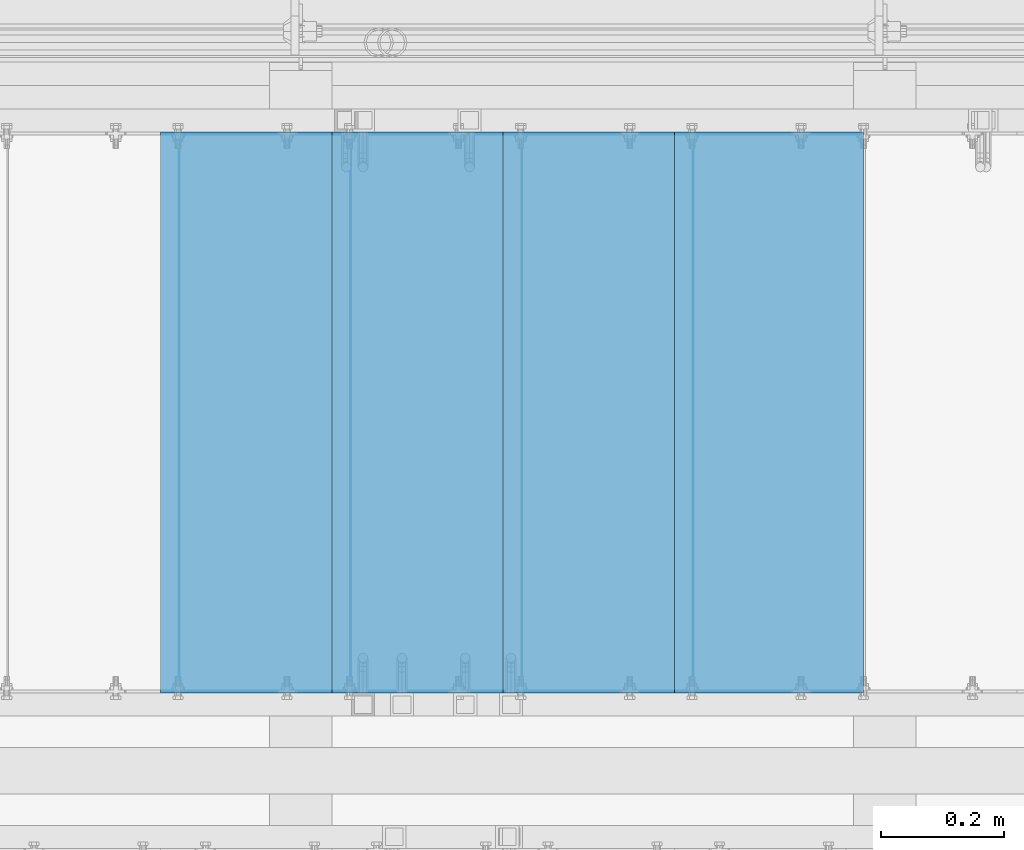
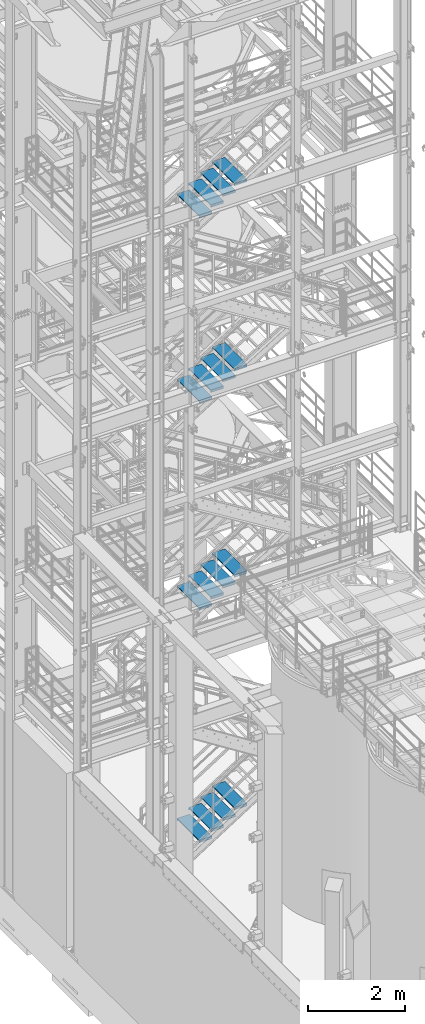
# One storey, part 1186 of 1876: 16 beams, 4 elements without a shape of their own.
"""IFC2X3 building model written with IfcOpenShell, lengths in millimetres."""

from ifc_helpers import new_model, si_unit, frame, origin_with_axes, place, context, subcontext, project, spatial, faceted_brep, material, type_object, element, aggregate, save


model = new_model("IFC2X3")

# Units and contexts
model_context = context("Model", 3, precision=1e-05, world=origin_with_axes())
body_context = subcontext(model_context, "Body", "Model", "MODEL_VIEW")
ifc_project = project(units=[si_unit("LENGTHUNIT", "METRE", prefix="MILLI"), si_unit("AREAUNIT", "SQUARE_METRE"), si_unit("VOLUMEUNIT", "CUBIC_METRE"), si_unit("MASSUNIT", "GRAM", prefix="KILO"), si_unit("TIMEUNIT", "SECOND"), si_unit("PLANEANGLEUNIT", "RADIAN"), si_unit("SOLIDANGLEUNIT", "STERADIAN"), si_unit("THERMODYNAMICTEMPERATUREUNIT", "DEGREE_CELSIUS"), si_unit("LUMINOUSINTENSITYUNIT", "LUMEN")], contexts=[model_context])

# Site, building, storey
site_placement = place(None, origin_with_axes())
site = spatial("IfcSite", under=ifc_project, at=site_placement, CompositionType="ELEMENT")
building_placement = place(site_placement, origin_with_axes())
building = spatial("IfcBuilding", under=site, at=building_placement, Name="Undefined", CompositionType="ELEMENT")
storey_placement = place(building_placement, origin_with_axes())
storey = spatial("IfcBuildingStorey", under=building, at=storey_placement, Name="Undefined", CompositionType="ELEMENT", Elevation=0.0)

# Assembly, beams
assembly_1_placement = place(storey_placement, origin_with_axes())
assembly_1 = element("IfcElementAssembly", 1, at=assembly_1_placement, inside=storey, Name="STRINGER", AssemblyPlace="NOTDEFINED", PredefinedType="RIGID_FRAME")
ifc_material = material(Name="STEEL/A36")
beam_type = type_object("IfcBeamType", PredefinedType="NOTDEFINED")
beam_1_placement = place(assembly_1_placement, frame((4573.58749594035, -5710.23700114434, 16944.6222227142), z_axis=(-1.0, 0.0, 0.0), x_axis=(0.0, 1.0, 0.0)))
beam_1 = element("IfcBeam", 2, at=beam_1_placement, type_object=beam_type, material=ifc_material, Name="TREAD", context=body_context, shape_type="Brep", body=[
    faceted_brep([(-7.45785655453801e-11, 53.9750000000167, -153.9875), (-7.45785655453801e-11, 53.9750000000167, 153.987506103515), (0.0, 9.52499999999964, 153.9875), (-7.45785655453801e-11, 9.52499999999964, -153.9875), (-4.76300000007541, 53.9750000000167, -153.9875), (-4.76300000007541, 53.9750000000167, 153.987506103515), (-4.76300000007541, -9.52499999998327, -153.9875), (-4.76300000007541, -9.52500000019427, 153.987536621094), (909.637000008669, -9.52500000248983, 153.987506103515), (909.637000008669, 53.9749999975102, 153.987506103515), (904.87400000867, 53.9749999975102, 153.987506103515), (904.87400000867, 9.52499999999964, 153.987506103515), (-7.45785655453801e-11, -9.52500000019427, 153.987536621094), (904.87400000867, -9.52500000248983, 153.987506103515), (904.87400000867, 9.52499999999964, -153.9875), (909.637000008669, -9.52500000248983, -153.9875), (909.637000008669, 53.9749999975102, -153.9875), (904.87400000867, 53.9749999975102, -153.9875)], [[[0, 1, 2, 3]], [[1, 0, 4, 5]], [[5, 4, 6, 7]], [[8, 9, 10, 11, 2, 1, 5, 7, 12, 13]], [[14, 3, 2, 11]], [[15, 8, 13, 12, 7, 6]], [[9, 16, 17, 10]], [[16, 9, 8, 15]], [[16, 15, 6, 4, 0, 3, 14, 17]], [[10, 17, 14, 11]]]),
])
beam_2_placement = place(assembly_1_placement, frame((4294.18749569463, -5710.23700114488, 16771.5259263061), z_axis=(-1.0, 0.0, 0.0), x_axis=(0.0, 1.0, 0.0)))
beam_2 = element("IfcBeam", 3, at=beam_2_placement, type_object=beam_type, material=ifc_material, Name="TREAD", context=body_context, shape_type="Brep", body=[
    faceted_brep([(-7.45785655453801e-11, 53.9750000000167, -153.9875), (-7.45785655453801e-11, 53.9750000000167, 153.987506103515), (0.0, 9.52499999999964, 153.9875), (-7.45785655453801e-11, 9.52499999999964, -153.9875), (-4.76300000007541, 53.9750000000167, -153.9875), (-4.76300000007541, 53.9750000000167, 153.987506103515), (-4.76300000007541, -9.52499999998327, -153.9875), (-4.76300000007541, -9.52500000019427, 153.987536621094), (909.637000008669, -9.52500000248983, 153.987506103515), (909.637000008669, 53.9749999975102, 153.987506103515), (904.87400000867, 53.9749999975102, 153.987506103515), (904.87400000867, 9.52499999999964, 153.987506103515), (-7.45785655453801e-11, -9.52500000019427, 153.987536621094), (904.87400000867, -9.52500000248983, 153.987506103515), (904.87400000867, 9.52499999999964, -153.9875), (909.637000008669, -9.52500000248983, -153.9875), (909.637000008669, 53.9749999975102, -153.9875), (904.87400000867, 53.9749999975102, -153.9875)], [[[0, 1, 2, 3]], [[1, 0, 4, 5]], [[5, 4, 6, 7]], [[8, 9, 10, 11, 2, 1, 5, 7, 12, 13]], [[14, 3, 2, 11]], [[15, 8, 13, 12, 7, 6]], [[9, 16, 17, 10]], [[16, 9, 8, 15]], [[16, 15, 6, 4, 0, 3, 14, 17]], [[10, 17, 14, 11]]]),
])
beam_3_placement = place(assembly_1_placement, frame((4014.7874954489, -5710.23700114541, 16598.4296298979), z_axis=(-1.0, 0.0, 0.0), x_axis=(0.0, 1.0, 0.0)))
beam_3 = element("IfcBeam", 4, at=beam_3_placement, type_object=beam_type, material=ifc_material, Name="TREAD", context=body_context, shape_type="Brep", body=[
    faceted_brep([(-7.45785655453801e-11, 53.9750000000167, -153.9875), (-7.45785655453801e-11, 53.9750000000167, 153.987506103515), (0.0, 9.52499999999964, 153.9875), (-7.45785655453801e-11, 9.52499999999964, -153.9875), (-4.76300000007541, 53.9750000000167, -153.9875), (-4.76300000007541, 53.9750000000167, 153.987506103515), (-4.76300000007541, -9.52499999998327, -153.9875), (-4.76300000007541, -9.52500000019427, 153.987536621094), (909.637000008669, -9.52500000248983, 153.987506103515), (909.637000008669, 53.9749999975102, 153.987506103515), (904.87400000867, 53.9749999975102, 153.987506103515), (904.87400000867, 9.52499999999964, 153.987506103515), (-7.45785655453801e-11, -9.52500000019427, 153.987536621094), (904.87400000867, -9.52500000248983, 153.987506103515), (904.87400000867, 9.52499999999964, -153.9875), (909.637000008669, -9.52500000248983, -153.9875), (909.637000008669, 53.9749999975102, -153.9875), (904.87400000867, 53.9749999975102, -153.9875)], [[[0, 1, 2, 3]], [[1, 0, 4, 5]], [[5, 4, 6, 7]], [[8, 9, 10, 11, 2, 1, 5, 7, 12, 13]], [[14, 3, 2, 11]], [[15, 8, 13, 12, 7, 6]], [[9, 16, 17, 10]], [[16, 9, 8, 15]], [[16, 15, 6, 4, 0, 3, 14, 17]], [[10, 17, 14, 11]]]),
])
beam_4_placement = place(assembly_1_placement, frame((3735.38749520317, -5710.23700114594, 16425.3333334898), z_axis=(-1.0, 0.0, 0.0), x_axis=(0.0, 1.0, 0.0)))
beam_4 = element("IfcBeam", 5, at=beam_4_placement, type_object=beam_type, material=ifc_material, Name="TREAD", context=body_context, shape_type="Brep", body=[
    faceted_brep([(-7.45785655453801e-11, 53.9750000000167, -153.9875), (-7.45785655453801e-11, 53.9750000000167, 153.987506103515), (0.0, 9.52499999999964, 153.9875), (-7.45785655453801e-11, 9.52499999999964, -153.9875), (-4.76300000007541, 53.9750000000167, -153.9875), (-4.76300000007541, 53.9750000000167, 153.987506103515), (-4.76300000007541, -9.52499999998327, -153.9875), (-4.76300000007541, -9.52500000019427, 153.987536621094), (909.637000008669, -9.52500000248983, 153.987506103515), (909.637000008669, 53.9749999975102, 153.987506103515), (904.87400000867, 53.9749999975102, 153.987506103515), (904.87400000867, 9.52499999999964, 153.987506103515), (-7.45785655453801e-11, -9.52500000019427, 153.987536621094), (904.87400000867, -9.52500000248983, 153.987506103515), (904.87400000867, 9.52499999999964, -153.9875), (909.637000008669, -9.52500000248983, -153.9875), (909.637000008669, 53.9749999975102, -153.9875), (904.87400000867, 53.9749999975102, -153.9875)], [[[0, 1, 2, 3]], [[1, 0, 4, 5]], [[5, 4, 6, 7]], [[8, 9, 10, 11, 2, 1, 5, 7, 12, 13]], [[14, 3, 2, 11]], [[15, 8, 13, 12, 7, 6]], [[9, 16, 17, 10]], [[16, 9, 8, 15]], [[16, 15, 6, 4, 0, 3, 14, 17]], [[10, 17, 14, 11]]]),
])
aggregate(assembly_1, [beam_1, beam_2, beam_3, beam_4])

assembly_2_placement = place(storey_placement, origin_with_axes())
assembly_2 = element("IfcElementAssembly", 6, at=assembly_2_placement, inside=storey, Name="STRINGER", AssemblyPlace="NOTDEFINED", PredefinedType="RIGID_FRAME")
beam_5_placement = place(assembly_2_placement, frame((4573.58750055376, -5710.23700114556, 12278.3600000199), z_axis=(-1.0, 0.0, 0.0), x_axis=(0.0, 1.0, 0.0)))
beam_5 = element("IfcBeam", 7, at=beam_5_placement, type_object=beam_type, material=ifc_material, Name="TREAD", context=body_context, shape_type="Brep", body=[
    faceted_brep([(-7.45785655453801e-11, 53.9750000000167, -153.9875), (-7.45785655453801e-11, 53.9750000000167, 153.987506103515), (0.0, 9.52499999999964, 153.9875), (-7.45785655453801e-11, 9.52499999999964, -153.9875), (-4.76300000007541, 53.9750000000167, -153.9875), (-4.76300000007541, 53.9750000000167, 153.987506103515), (-4.76300000007541, -9.52499999998327, -153.9875), (-4.76300000007541, -9.52500000019427, 153.987536621094), (909.637000008669, -9.52500000248983, 153.987506103515), (909.637000008669, 53.9749999975102, 153.987506103515), (904.87400000867, 53.9749999975102, 153.987506103515), (904.87400000867, 9.52499999999964, 153.987506103515), (-7.45785655453801e-11, -9.52500000019427, 153.987536621094), (904.87400000867, -9.52500000248983, 153.987506103515), (904.87400000867, 9.52499999999964, -153.9875), (909.637000008669, -9.52500000248983, -153.9875), (909.637000008669, 53.9749999975102, -153.9875), (904.87400000867, 53.9749999975102, -153.9875)], [[[0, 1, 2, 3]], [[1, 0, 4, 5]], [[5, 4, 6, 7]], [[8, 9, 10, 11, 2, 1, 5, 7, 12, 13]], [[14, 3, 2, 11]], [[15, 8, 13, 12, 7, 6]], [[9, 16, 17, 10]], [[16, 9, 8, 15]], [[16, 15, 6, 4, 0, 3, 14, 17]], [[10, 17, 14, 11]]]),
])
beam_6_placement = place(assembly_2_placement, frame((4294.18750064748, -5710.23700114556, 12106.4866666865), z_axis=(-1.0, 0.0, 0.0), x_axis=(0.0, 1.0, 0.0)))
beam_6 = element("IfcBeam", 8, at=beam_6_placement, type_object=beam_type, material=ifc_material, Name="TREAD", context=body_context, shape_type="Brep", body=[
    faceted_brep([(-7.45785655453801e-11, 53.9750000000167, -153.9875), (-7.45785655453801e-11, 53.9750000000167, 153.987506103515), (0.0, 9.52499999999964, 153.9875), (-7.45785655453801e-11, 9.52499999999964, -153.9875), (-4.76300000007541, 53.9750000000167, -153.9875), (-4.76300000007541, 53.9750000000167, 153.987506103515), (-4.76300000007541, -9.52499999998327, -153.9875), (-4.76300000007541, -9.52500000019427, 153.987536621094), (909.637000008669, -9.52500000248983, 153.987506103515), (909.637000008669, 53.9749999975102, 153.987506103515), (904.87400000867, 53.9749999975102, 153.987506103515), (904.87400000867, 9.52499999999964, 153.987506103515), (-7.45785655453801e-11, -9.52500000019427, 153.987536621094), (904.87400000867, -9.52500000248983, 153.987506103515), (904.87400000867, 9.52499999999964, -153.9875), (909.637000008669, -9.52500000248983, -153.9875), (909.637000008669, 53.9749999975102, -153.9875), (904.87400000867, 53.9749999975102, -153.9875)], [[[0, 1, 2, 3]], [[1, 0, 4, 5]], [[5, 4, 6, 7]], [[8, 9, 10, 11, 2, 1, 5, 7, 12, 13]], [[14, 3, 2, 11]], [[15, 8, 13, 12, 7, 6]], [[9, 16, 17, 10]], [[16, 9, 8, 15]], [[16, 15, 6, 4, 0, 3, 14, 17]], [[10, 17, 14, 11]]]),
])
beam_7_placement = place(assembly_2_placement, frame((4014.7875007412, -5710.23700114556, 11934.6133333532), z_axis=(-1.0, 0.0, 0.0), x_axis=(0.0, 1.0, 0.0)))
beam_7 = element("IfcBeam", 9, at=beam_7_placement, type_object=beam_type, material=ifc_material, Name="TREAD", context=body_context, shape_type="Brep", body=[
    faceted_brep([(-7.45785655453801e-11, 53.9750000000167, -153.9875), (-7.45785655453801e-11, 53.9750000000167, 153.987506103515), (0.0, 9.52499999999964, 153.9875), (-7.45785655453801e-11, 9.52499999999964, -153.9875), (-4.76300000007541, 53.9750000000167, -153.9875), (-4.76300000007541, 53.9750000000167, 153.987506103515), (-4.76300000007541, -9.52499999998327, -153.9875), (-4.76300000007541, -9.52500000019427, 153.987536621094), (909.637000008669, -9.52500000248983, 153.987506103515), (909.637000008669, 53.9749999975102, 153.987506103515), (904.87400000867, 53.9749999975102, 153.987506103515), (904.87400000867, 9.52499999999964, 153.987506103515), (-7.45785655453801e-11, -9.52500000019427, 153.987536621094), (904.87400000867, -9.52500000248983, 153.987506103515), (904.87400000867, 9.52499999999964, -153.9875), (909.637000008669, -9.52500000248983, -153.9875), (909.637000008669, 53.9749999975102, -153.9875), (904.87400000867, 53.9749999975102, -153.9875)], [[[0, 1, 2, 3]], [[1, 0, 4, 5]], [[5, 4, 6, 7]], [[8, 9, 10, 11, 2, 1, 5, 7, 12, 13]], [[14, 3, 2, 11]], [[15, 8, 13, 12, 7, 6]], [[9, 16, 17, 10]], [[16, 9, 8, 15]], [[16, 15, 6, 4, 0, 3, 14, 17]], [[10, 17, 14, 11]]]),
])
beam_8_placement = place(assembly_2_placement, frame((3735.38750083493, -5710.23700114556, 11762.7400000199), z_axis=(-1.0, 0.0, 0.0), x_axis=(0.0, 1.0, 0.0)))
beam_8 = element("IfcBeam", 10, at=beam_8_placement, type_object=beam_type, material=ifc_material, Name="TREAD", context=body_context, shape_type="Brep", body=[
    faceted_brep([(-7.45785655453801e-11, 53.9750000000167, -153.9875), (-7.45785655453801e-11, 53.9750000000167, 153.987506103515), (0.0, 9.52499999999964, 153.9875), (-7.45785655453801e-11, 9.52499999999964, -153.9875), (-4.76300000007541, 53.9750000000167, -153.9875), (-4.76300000007541, 53.9750000000167, 153.987506103515), (-4.76300000007541, -9.52499999998327, -153.9875), (-4.76300000007541, -9.52500000019427, 153.987536621094), (909.637000008669, -9.52500000248983, 153.987506103515), (909.637000008669, 53.9749999975102, 153.987506103515), (904.87400000867, 53.9749999975102, 153.987506103515), (904.87400000867, 9.52499999999964, 153.987506103515), (-7.45785655453801e-11, -9.52500000019427, 153.987536621094), (904.87400000867, -9.52500000248983, 153.987506103515), (904.87400000867, 9.52499999999964, -153.9875), (909.637000008669, -9.52500000248983, -153.9875), (909.637000008669, 53.9749999975102, -153.9875), (904.87400000867, 53.9749999975102, -153.9875)], [[[0, 1, 2, 3]], [[1, 0, 4, 5]], [[5, 4, 6, 7]], [[8, 9, 10, 11, 2, 1, 5, 7, 12, 13]], [[14, 3, 2, 11]], [[15, 8, 13, 12, 7, 6]], [[9, 16, 17, 10]], [[16, 9, 8, 15]], [[16, 15, 6, 4, 0, 3, 14, 17]], [[10, 17, 14, 11]]]),
])
aggregate(assembly_2, [beam_5, beam_6, beam_7, beam_8])

assembly_3_placement = place(storey_placement, origin_with_axes())
assembly_3 = element("IfcElementAssembly", 11, at=assembly_3_placement, inside=storey, Name="STRINGER", AssemblyPlace="NOTDEFINED", PredefinedType="RIGID_FRAME")
beam_9_placement = place(assembly_3_placement, frame((4573.58749641571, -5710.23700113625, 7086.59999911074), z_axis=(-1.0, 0.0, 0.0), x_axis=(0.0, 1.0, 0.0)))
beam_9 = element("IfcBeam", 12, at=beam_9_placement, type_object=beam_type, material=ifc_material, Name="TREAD", context=body_context, shape_type="Brep", body=[
    faceted_brep([(-7.45785655453801e-11, 53.9750000000167, -153.9875), (-7.45785655453801e-11, 53.9750000000167, 153.987506103515), (0.0, 9.52499999999964, 153.9875), (-7.45785655453801e-11, 9.52499999999964, -153.9875), (-4.76300000007541, 53.9750000000167, -153.9875), (-4.76300000007541, 53.9750000000167, 153.987506103515), (-4.76300000007541, -9.52499999998327, -153.9875), (-4.76300000007541, -9.52500000019427, 153.987536621094), (909.637000008669, -9.52500000248983, 153.987506103515), (909.637000008669, 53.9749999975102, 153.987506103515), (904.87400000867, 53.9749999975102, 153.987506103515), (904.87400000867, 9.52499999999964, 153.987506103515), (-7.45785655453801e-11, -9.52500000019427, 153.987536621094), (904.87400000867, -9.52500000248983, 153.987506103515), (904.87400000867, 9.52499999999964, -153.9875), (909.637000008669, -9.52500000248983, -153.9875), (909.637000008669, 53.9749999975102, -153.9875), (904.87400000867, 53.9749999975102, -153.9875)], [[[0, 1, 2, 3]], [[1, 0, 4, 5]], [[5, 4, 6, 7]], [[8, 9, 10, 11, 2, 1, 5, 7, 12, 13]], [[14, 3, 2, 11]], [[15, 8, 13, 12, 7, 6]], [[9, 16, 17, 10]], [[16, 9, 8, 15]], [[16, 15, 6, 4, 0, 3, 14, 17]], [[10, 17, 14, 11]]]),
])
beam_10_placement = place(assembly_3_placement, frame((4294.18749680581, -5710.23700113625, 6908.7999991915), z_axis=(-1.0, 0.0, 0.0), x_axis=(0.0, 1.0, 0.0)))
beam_10 = element("IfcBeam", 13, at=beam_10_placement, type_object=beam_type, material=ifc_material, Name="TREAD", context=body_context, shape_type="Brep", body=[
    faceted_brep([(-7.45785655453801e-11, 53.9750000000167, -153.9875), (-7.45785655453801e-11, 53.9750000000167, 153.987506103515), (0.0, 9.52499999999964, 153.9875), (-7.45785655453801e-11, 9.52499999999964, -153.9875), (-4.76300000007541, 53.9750000000167, -153.9875), (-4.76300000007541, 53.9750000000167, 153.987506103515), (-4.76300000007541, -9.52499999998327, -153.9875), (-4.76300000007541, -9.52500000019427, 153.987536621094), (909.637000008669, -9.52500000248983, 153.987506103515), (909.637000008669, 53.9749999975102, 153.987506103515), (904.87400000867, 53.9749999975102, 153.987506103515), (904.87400000867, 9.52499999999964, 153.987506103515), (-7.45785655453801e-11, -9.52500000019427, 153.987536621094), (904.87400000867, -9.52500000248983, 153.987506103515), (904.87400000867, 9.52499999999964, -153.9875), (909.637000008669, -9.52500000248983, -153.9875), (909.637000008669, 53.9749999975102, -153.9875), (904.87400000867, 53.9749999975102, -153.9875)], [[[0, 1, 2, 3]], [[1, 0, 4, 5]], [[5, 4, 6, 7]], [[8, 9, 10, 11, 2, 1, 5, 7, 12, 13]], [[14, 3, 2, 11]], [[15, 8, 13, 12, 7, 6]], [[9, 16, 17, 10]], [[16, 9, 8, 15]], [[16, 15, 6, 4, 0, 3, 14, 17]], [[10, 17, 14, 11]]]),
])
beam_11_placement = place(assembly_3_placement, frame((4014.7874971959, -5710.23700113625, 6730.99999927227), z_axis=(-1.0, 0.0, 0.0), x_axis=(0.0, 1.0, 0.0)))
beam_11 = element("IfcBeam", 14, at=beam_11_placement, type_object=beam_type, material=ifc_material, Name="TREAD", context=body_context, shape_type="Brep", body=[
    faceted_brep([(-7.45785655453801e-11, 53.9750000000167, -153.9875), (-7.45785655453801e-11, 53.9750000000167, 153.987506103515), (0.0, 9.52499999999964, 153.9875), (-7.45785655453801e-11, 9.52499999999964, -153.9875), (-4.76300000007541, 53.9750000000167, -153.9875), (-4.76300000007541, 53.9750000000167, 153.987506103515), (-4.76300000007541, -9.52499999998327, -153.9875), (-4.76300000007541, -9.52500000019427, 153.987536621094), (909.637000008669, -9.52500000248983, 153.987506103515), (909.637000008669, 53.9749999975102, 153.987506103515), (904.87400000867, 53.9749999975102, 153.987506103515), (904.87400000867, 9.52499999999964, 153.987506103515), (-7.45785655453801e-11, -9.52500000019427, 153.987536621094), (904.87400000867, -9.52500000248983, 153.987506103515), (904.87400000867, 9.52499999999964, -153.9875), (909.637000008669, -9.52500000248983, -153.9875), (909.637000008669, 53.9749999975102, -153.9875), (904.87400000867, 53.9749999975102, -153.9875)], [[[0, 1, 2, 3]], [[1, 0, 4, 5]], [[5, 4, 6, 7]], [[8, 9, 10, 11, 2, 1, 5, 7, 12, 13]], [[14, 3, 2, 11]], [[15, 8, 13, 12, 7, 6]], [[9, 16, 17, 10]], [[16, 9, 8, 15]], [[16, 15, 6, 4, 0, 3, 14, 17]], [[10, 17, 14, 11]]]),
])
beam_12_placement = place(assembly_3_placement, frame((3735.38749758599, -5710.23700113625, 6553.19999935304), z_axis=(-1.0, 0.0, 0.0), x_axis=(0.0, 1.0, 0.0)))
beam_12 = element("IfcBeam", 15, at=beam_12_placement, type_object=beam_type, material=ifc_material, Name="TREAD", context=body_context, shape_type="Brep", body=[
    faceted_brep([(-7.45785655453801e-11, 53.9750000000167, -153.9875), (-7.45785655453801e-11, 53.9750000000167, 153.987506103515), (0.0, 9.52499999999964, 153.9875), (-7.45785655453801e-11, 9.52499999999964, -153.9875), (-4.76300000007541, 53.9750000000167, -153.9875), (-4.76300000007541, 53.9750000000167, 153.987506103515), (-4.76300000007541, -9.52499999998327, -153.9875), (-4.76300000007541, -9.52500000019427, 153.987536621094), (909.637000008669, -9.52500000248983, 153.987506103515), (909.637000008669, 53.9749999975102, 153.987506103515), (904.87400000867, 53.9749999975102, 153.987506103515), (904.87400000867, 9.52499999999964, 153.987506103515), (-7.45785655453801e-11, -9.52500000019427, 153.987536621094), (904.87400000867, -9.52500000248983, 153.987506103515), (904.87400000867, 9.52499999999964, -153.9875), (909.637000008669, -9.52500000248983, -153.9875), (909.637000008669, 53.9749999975102, -153.9875), (904.87400000867, 53.9749999975102, -153.9875)], [[[0, 1, 2, 3]], [[1, 0, 4, 5]], [[5, 4, 6, 7]], [[8, 9, 10, 11, 2, 1, 5, 7, 12, 13]], [[14, 3, 2, 11]], [[15, 8, 13, 12, 7, 6]], [[9, 16, 17, 10]], [[16, 9, 8, 15]], [[16, 15, 6, 4, 0, 3, 14, 17]], [[10, 17, 14, 11]]]),
])
aggregate(assembly_3, [beam_9, beam_10, beam_11, beam_12])

assembly_4_placement = place(storey_placement, origin_with_axes())
assembly_4 = element("IfcElementAssembly", 16, at=assembly_4_placement, inside=storey, Name="STRINGER", AssemblyPlace="NOTDEFINED", PredefinedType="RIGID_FRAME")
beam_13_placement = place(assembly_4_placement, frame((4573.58750052602, -5710.23700121136, 1231.24310314779), z_axis=(-1.0, 0.0, 0.0), x_axis=(0.0, 1.0, 0.0)))
beam_13 = element("IfcBeam", 17, at=beam_13_placement, type_object=beam_type, material=ifc_material, Name="TREAD", context=body_context, shape_type="Brep", body=[
    faceted_brep([(-7.45785655453801e-11, 53.9750000000167, -153.9875), (-7.45785655453801e-11, 53.9750000000167, 153.987506103515), (0.0, 9.52499999999964, 153.9875), (-7.45785655453801e-11, 9.52499999999964, -153.9875), (-4.76300000007541, 53.9750000000167, -153.9875), (-4.76300000007541, 53.9750000000167, 153.987506103515), (-4.76300000007541, -9.52499999998327, -153.9875), (-4.76300000007541, -9.52500000019427, 153.987536621094), (909.637000008669, -9.52500000248983, 153.987506103515), (909.637000008669, 53.9749999975102, 153.987506103515), (904.87400000867, 53.9749999975102, 153.987506103515), (904.87400000867, 9.52499999999964, 153.987506103515), (-7.45785655453801e-11, -9.52500000019427, 153.987536621094), (904.87400000867, -9.52500000248983, 153.987506103515), (904.87400000867, 9.52499999999964, -153.9875), (909.637000008669, -9.52500000248983, -153.9875), (909.637000008669, 53.9749999975102, -153.9875), (904.87400000867, 53.9749999975102, -153.9875)], [[[0, 1, 2, 3]], [[1, 0, 4, 5]], [[5, 4, 6, 7]], [[8, 9, 10, 11, 2, 1, 5, 7, 12, 13]], [[14, 3, 2, 11]], [[15, 8, 13, 12, 7, 6]], [[9, 16, 17, 10]], [[16, 9, 8, 15]], [[16, 15, 6, 4, 0, 3, 14, 17]], [[10, 17, 14, 11]]]),
])
beam_14_placement = place(assembly_4_placement, frame((4294.18750049885, -5710.23700121136, 1053.99051698372), z_axis=(-1.0, 0.0, 0.0), x_axis=(0.0, 1.0, 0.0)))
beam_14 = element("IfcBeam", 18, at=beam_14_placement, type_object=beam_type, material=ifc_material, Name="TREAD", context=body_context, shape_type="Brep", body=[
    faceted_brep([(-7.45785655453801e-11, 53.9750000000167, -153.9875), (-7.45785655453801e-11, 53.9750000000167, 153.987506103515), (0.0, 9.52499999999964, 153.9875), (-7.45785655453801e-11, 9.52499999999964, -153.9875), (-4.76300000007541, 53.9750000000167, -153.9875), (-4.76300000007541, 53.9750000000167, 153.987506103515), (-4.76300000007541, -9.52499999998327, -153.9875), (-4.76300000007541, -9.52500000019427, 153.987536621094), (909.637000008669, -9.52500000248983, 153.987506103515), (909.637000008669, 53.9749999975102, 153.987506103515), (904.87400000867, 53.9749999975102, 153.987506103515), (904.87400000867, 9.52499999999964, 153.987506103515), (-7.45785655453801e-11, -9.52500000019427, 153.987536621094), (904.87400000867, -9.52500000248983, 153.987506103515), (904.87400000867, 9.52499999999964, -153.9875), (909.637000008669, -9.52500000248983, -153.9875), (909.637000008669, 53.9749999975102, -153.9875), (904.87400000867, 53.9749999975102, -153.9875)], [[[0, 1, 2, 3]], [[1, 0, 4, 5]], [[5, 4, 6, 7]], [[8, 9, 10, 11, 2, 1, 5, 7, 12, 13]], [[14, 3, 2, 11]], [[15, 8, 13, 12, 7, 6]], [[9, 16, 17, 10]], [[16, 9, 8, 15]], [[16, 15, 6, 4, 0, 3, 14, 17]], [[10, 17, 14, 11]]]),
])
beam_15_placement = place(assembly_4_placement, frame((4014.78750047168, -5710.23700121136, 876.737930819664), z_axis=(-1.0, 0.0, 0.0), x_axis=(0.0, 1.0, 0.0)))
beam_15 = element("IfcBeam", 19, at=beam_15_placement, type_object=beam_type, material=ifc_material, Name="TREAD", context=body_context, shape_type="Brep", body=[
    faceted_brep([(-7.45785655453801e-11, 53.9750000000167, -153.9875), (-7.45785655453801e-11, 53.9750000000167, 153.987506103515), (0.0, 9.52499999999964, 153.9875), (-7.45785655453801e-11, 9.52499999999964, -153.9875), (-4.76300000007541, 53.9750000000167, -153.9875), (-4.76300000007541, 53.9750000000167, 153.987506103515), (-4.76300000007541, -9.52499999998327, -153.9875), (-4.76300000007541, -9.52500000019427, 153.987536621094), (909.637000008669, -9.52500000248983, 153.987506103515), (909.637000008669, 53.9749999975102, 153.987506103515), (904.87400000867, 53.9749999975102, 153.987506103515), (904.87400000867, 9.52499999999964, 153.987506103515), (-7.45785655453801e-11, -9.52500000019427, 153.987536621094), (904.87400000867, -9.52500000248983, 153.987506103515), (904.87400000867, 9.52499999999964, -153.9875), (909.637000008669, -9.52500000248983, -153.9875), (909.637000008669, 53.9749999975102, -153.9875), (904.87400000867, 53.9749999975102, -153.9875)], [[[0, 1, 2, 3]], [[1, 0, 4, 5]], [[5, 4, 6, 7]], [[8, 9, 10, 11, 2, 1, 5, 7, 12, 13]], [[14, 3, 2, 11]], [[15, 8, 13, 12, 7, 6]], [[9, 16, 17, 10]], [[16, 9, 8, 15]], [[16, 15, 6, 4, 0, 3, 14, 17]], [[10, 17, 14, 11]]]),
])
beam_16_placement = place(assembly_4_placement, frame((3735.38750044451, -5710.23700121136, 699.485344655628), z_axis=(-1.0, 0.0, 0.0), x_axis=(0.0, 1.0, 0.0)))
beam_16 = element("IfcBeam", 20, at=beam_16_placement, type_object=beam_type, material=ifc_material, Name="TREAD", context=body_context, shape_type="Brep", body=[
    faceted_brep([(-7.45785655453801e-11, 53.9750000000167, -153.9875), (-7.45785655453801e-11, 53.9750000000167, 153.987506103515), (0.0, 9.52499999999964, 153.9875), (-7.45785655453801e-11, 9.52499999999964, -153.9875), (-4.76300000007541, 53.9750000000167, -153.9875), (-4.76300000007541, 53.9750000000167, 153.987506103515), (-4.76300000007541, -9.52499999998327, -153.9875), (-4.76300000007541, -9.52500000019427, 153.987536621094), (909.637000008669, -9.52500000248983, 153.987506103515), (909.637000008669, 53.9749999975102, 153.987506103515), (904.87400000867, 53.9749999975102, 153.987506103515), (904.87400000867, 9.52499999999964, 153.987506103515), (-7.45785655453801e-11, -9.52500000019427, 153.987536621094), (904.87400000867, -9.52500000248983, 153.987506103515), (904.87400000867, 9.52499999999964, -153.9875), (909.637000008669, -9.52500000248983, -153.9875), (909.637000008669, 53.9749999975102, -153.9875), (904.87400000867, 53.9749999975102, -153.9875)], [[[0, 1, 2, 3]], [[1, 0, 4, 5]], [[5, 4, 6, 7]], [[8, 9, 10, 11, 2, 1, 5, 7, 12, 13]], [[14, 3, 2, 11]], [[15, 8, 13, 12, 7, 6]], [[9, 16, 17, 10]], [[16, 9, 8, 15]], [[16, 15, 6, 4, 0, 3, 14, 17]], [[10, 17, 14, 11]]]),
])
aggregate(assembly_4, [beam_13, beam_14, beam_15, beam_16])

save(model, "model.ifc")
